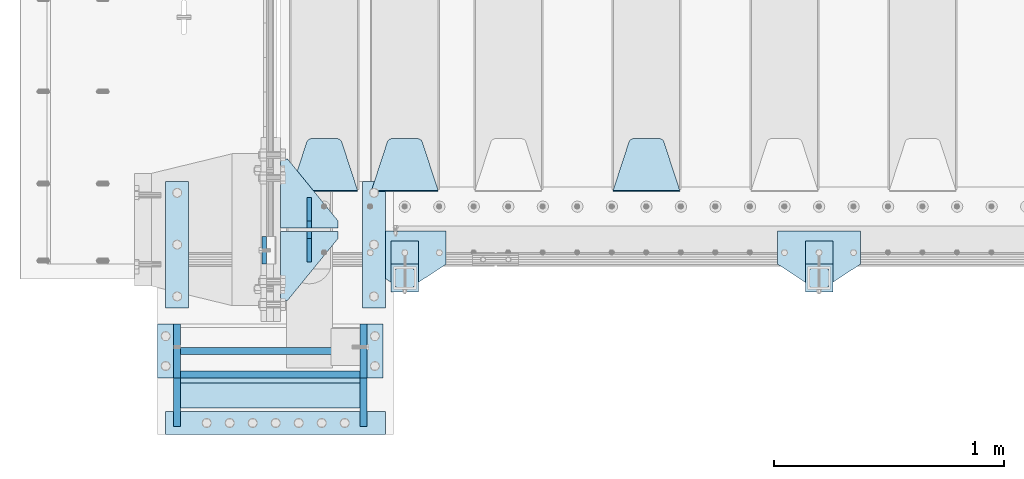
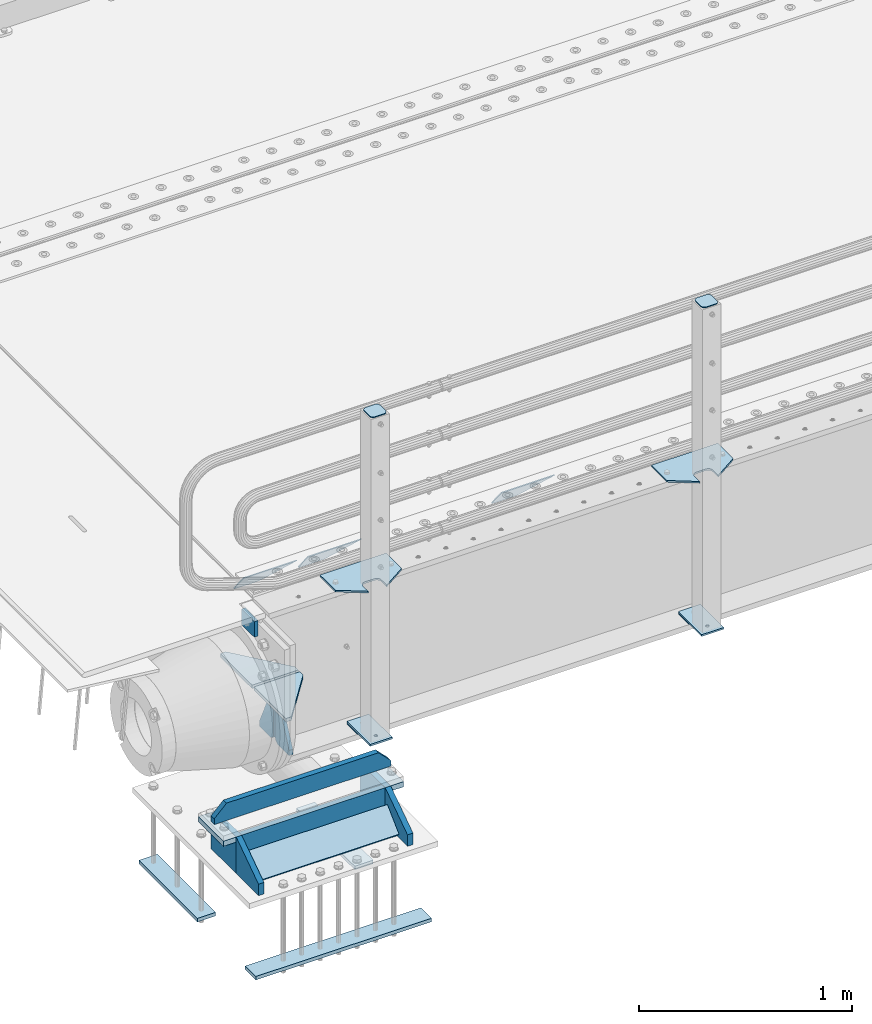
# One storey, part 166 of 208: 28 plates.
"""IFC2X3 building model written with IfcOpenShell, lengths in millimetres."""

from ifc_helpers import new_model, si_unit, frame, origin_with_axes, place, context, subcontext, project, spatial, faceted_brep, material, type_object, element, save


model = new_model("IFC2X3")

# Units and contexts
model_context = context("Model", 3, precision=1e-05, world=origin_with_axes())
body_context = subcontext(model_context, "Body", "Model", "MODEL_VIEW")
ifc_project = project(units=[si_unit("LENGTHUNIT", "METRE", prefix="MILLI"), si_unit("AREAUNIT", "SQUARE_METRE"), si_unit("VOLUMEUNIT", "CUBIC_METRE"), si_unit("MASSUNIT", "GRAM", prefix="KILO"), si_unit("TIMEUNIT", "SECOND"), si_unit("PLANEANGLEUNIT", "RADIAN"), si_unit("SOLIDANGLEUNIT", "STERADIAN"), si_unit("THERMODYNAMICTEMPERATUREUNIT", "DEGREE_CELSIUS"), si_unit("LUMINOUSINTENSITYUNIT", "LUMEN")], contexts=[model_context])

# Site, building, storey
site_placement = place(None, origin_with_axes())
site = spatial("IfcSite", under=ifc_project, at=site_placement, CompositionType="ELEMENT")
building_placement = place(site_placement, origin_with_axes())
building = spatial("IfcBuilding", under=site, at=building_placement, Name="Standard", CompositionType="ELEMENT")
storey_placement = place(building_placement, origin_with_axes())
storey = spatial("IfcBuildingStorey", under=building, at=storey_placement, Name="Undefined", CompositionType="ELEMENT", Elevation=0.0)

# Plates
ifc_material_1 = material(Name="STEEL/S355N")
plate_type_1 = type_object("IfcPlateType", PredefinedType="NOTDEFINED")
plate_1_placement = place(storey_placement, frame((-42510.0, -29.9995540188065, -106.00008741594), z_axis=(1.0000003385235e-09, -0.999999999987744, -4.95099999993936e-06), x_axis=(0.0, -4.95099999998473e-06, 0.999999999987744)))
element("IfcPlate", 1, at=plate_1_placement, inside=storey, type_object=plate_type_1, material=ifc_material_1, context=body_context, shape_type="Brep", body=[
    faceted_brep([(0.0, -10.0, 0.0), (5.7072624315424e-07, -10.0, 120.0), (5.7072624315424e-07, 10.0, 120.0), (0.0, 10.0, 0.0), (90.0, -10.0, 120.0), (90.0, 10.0, 120.0), (90.0, -10.0, 1.09139364212751e-11), (90.0, 10.0, 1.09139364212751e-11)], [[[0, 1, 2, 3]], [[1, 4, 5, 2]], [[4, 6, 7, 5]], [[6, 0, 3, 7]], [[5, 7, 3, 2]], [[6, 4, 1, 0]]]),
])
plate_type_2 = type_object("IfcPlateType", PredefinedType="NOTDEFINED")
plate_2_placement = place(storey_placement, frame((-40705.0, 168.232233047023, -1.76776695296758), z_axis=(0.0, 0.707106781186547, -0.707106781186548), x_axis=(-1.0, 0.0, 0.0)))
element("IfcPlate", 2, at=plate_2_placement, inside=storey, type_object=plate_type_2, material=ifc_material_1, context=body_context, shape_type="Brep", body=[
    faceted_brep([(0.0, -2.5, 0.0), (69.345504679477, -2.5, 300.17173142483), (69.345504679477, 2.5, 300.17173142483), (0.0, 2.5, 0.0), (70.9274061199576, -2.5, 304.897442415399), (70.9274061199576, 2.5, 304.8974424154), (73.3818627772307, -2.5, 309.234538108527), (73.3818627772307, 2.5, 309.234538108527), (76.6187032999551, -2.5, 313.023683126103), (76.6187032999551, 2.5, 313.023683126103), (80.5190132704993, -2.5, 316.125672595371), (80.5190132704993, 2.5, 316.125672595371), (84.9395038596849, -2.5, 318.426546230476), (84.9395038596849, 2.50000000000091, 318.426546230476), (89.7177759439219, -2.5, 319.841774983275), (89.7177759439219, 2.50000000000091, 319.841774983275), (94.678286292652, -2.49999999999909, 320.319366455078), (94.678286292652, 2.5, 320.319366455078), (195.321713707348, -2.49999999999909, 320.319366455078), (195.321713707348, 2.5, 320.319366455078), (200.282224056078, -2.5, 319.841774983275), (200.282224056078, 2.5, 319.841774983274), (205.060496140315, -2.5, 318.426546230475), (205.060496140315, 2.5, 318.426546230475), (209.480986729501, -2.5, 316.125672595371), (209.480986729501, 2.50000000000091, 316.125672595371), (213.381296700045, -2.5, 313.023683126102), (213.381296700045, 2.5, 313.023683126102), (216.618137222769, -2.5, 309.234538108526), (216.618137222769, 2.5, 309.234538108527), (219.072593880042, -2.5, 304.897442415399), (219.072593880042, 2.5, 304.897442415399), (220.654495320523, -2.5, 300.17173142483), (220.654495320523, 2.5, 300.17173142483), (290.0, -2.5, 0.0), (290.0, 2.5, 0.0)], [[[0, 1, 2, 3]], [[1, 4, 5, 2]], [[4, 6, 7, 5]], [[6, 8, 9, 7]], [[8, 10, 11, 9]], [[10, 12, 13, 11]], [[12, 14, 15, 13]], [[14, 16, 17, 15]], [[16, 18, 19, 17]], [[18, 20, 21, 19]], [[20, 22, 23, 21]], [[22, 24, 25, 23]], [[24, 26, 27, 25]], [[26, 28, 29, 27]], [[28, 30, 31, 29]], [[30, 32, 33, 31]], [[32, 34, 35, 33]], [[34, 0, 3, 35]], [[5, 7, 9, 11, 13, 15, 17, 19, 21, 23, 25, 27, 29, 31, 33, 35, 3, 2]], [[34, 32, 30, 28, 26, 24, 22, 20, 18, 16, 14, 12, 10, 8, 6, 4, 1, 0]]]),
])
plate_3_placement = place(storey_placement, frame((-41755.0, 168.232233047023, -1.76776695296758), z_axis=(0.0, 0.707106781186547, -0.707106781186548), x_axis=(-1.0, 0.0, 0.0)))
element("IfcPlate", 3, at=plate_3_placement, inside=storey, type_object=plate_type_2, material=ifc_material_1, context=body_context, shape_type="Brep", body=[
    faceted_brep([(0.0, -2.5, 0.0), (69.345504679477, -2.5, 300.17173142483), (69.345504679477, 2.5, 300.17173142483), (0.0, 2.5, 0.0), (70.9274061199576, -2.5, 304.897442415399), (70.9274061199576, 2.5, 304.8974424154), (73.3818627772307, -2.5, 309.234538108527), (73.3818627772307, 2.5, 309.234538108527), (76.6187032999551, -2.5, 313.023683126103), (76.6187032999551, 2.5, 313.023683126103), (80.5190132704993, -2.5, 316.125672595371), (80.5190132704993, 2.5, 316.125672595371), (84.9395038596849, -2.5, 318.426546230476), (84.9395038596849, 2.50000000000091, 318.426546230476), (89.7177759439219, -2.5, 319.841774983275), (89.7177759439219, 2.50000000000091, 319.841774983275), (94.678286292652, -2.49999999999909, 320.319366455078), (94.678286292652, 2.5, 320.319366455078), (195.321713707348, -2.49999999999909, 320.319366455078), (195.321713707348, 2.5, 320.319366455078), (200.282224056078, -2.5, 319.841774983275), (200.282224056078, 2.5, 319.841774983274), (205.060496140315, -2.5, 318.426546230475), (205.060496140315, 2.5, 318.426546230475), (209.480986729501, -2.5, 316.125672595371), (209.480986729501, 2.50000000000091, 316.125672595371), (213.381296700045, -2.5, 313.023683126102), (213.381296700045, 2.5, 313.023683126102), (216.618137222769, -2.5, 309.234538108526), (216.618137222769, 2.5, 309.234538108527), (219.072593880042, -2.5, 304.897442415399), (219.072593880042, 2.5, 304.897442415399), (220.654495320523, -2.5, 300.17173142483), (220.654495320523, 2.5, 300.17173142483), (290.0, -2.5, 0.0), (290.0, 2.5, 0.0)], [[[0, 1, 2, 3]], [[1, 4, 5, 2]], [[4, 6, 7, 5]], [[6, 8, 9, 7]], [[8, 10, 11, 9]], [[10, 12, 13, 11]], [[12, 14, 15, 13]], [[14, 16, 17, 15]], [[16, 18, 19, 17]], [[18, 20, 21, 19]], [[20, 22, 23, 21]], [[22, 24, 25, 23]], [[24, 26, 27, 25]], [[26, 28, 29, 27]], [[28, 30, 31, 29]], [[30, 32, 33, 31]], [[32, 34, 35, 33]], [[34, 0, 3, 35]], [[5, 7, 9, 11, 13, 15, 17, 19, 21, 23, 25, 27, 29, 31, 33, 35, 3, 2]], [[34, 32, 30, 28, 26, 24, 22, 20, 18, 16, 14, 12, 10, 8, 6, 4, 1, 0]]]),
])
plate_4_placement = place(storey_placement, frame((-42105.0, 168.232233047023, -1.76776695296758), z_axis=(0.0, 0.707106781186547, -0.707106781186548), x_axis=(-1.0, 0.0, 0.0)))
element("IfcPlate", 4, at=plate_4_placement, inside=storey, type_object=plate_type_2, material=ifc_material_1, context=body_context, shape_type="Brep", body=[
    faceted_brep([(0.0, -2.5, 0.0), (69.345504679477, -2.5, 300.17173142483), (69.345504679477, 2.5, 300.17173142483), (0.0, 2.5, 0.0), (70.9274061199576, -2.5, 304.897442415399), (70.9274061199576, 2.5, 304.8974424154), (73.3818627772307, -2.5, 309.234538108527), (73.3818627772307, 2.5, 309.234538108527), (76.6187032999551, -2.5, 313.023683126103), (76.6187032999551, 2.5, 313.023683126103), (80.5190132704993, -2.5, 316.125672595371), (80.5190132704993, 2.5, 316.125672595371), (84.9395038596849, -2.5, 318.426546230476), (84.9395038596849, 2.50000000000091, 318.426546230476), (89.7177759439219, -2.5, 319.841774983275), (89.7177759439219, 2.50000000000091, 319.841774983275), (94.678286292652, -2.49999999999909, 320.319366455078), (94.678286292652, 2.5, 320.319366455078), (195.321713707348, -2.49999999999909, 320.319366455078), (195.321713707348, 2.5, 320.319366455078), (200.282224056078, -2.5, 319.841774983275), (200.282224056078, 2.5, 319.841774983274), (205.060496140315, -2.5, 318.426546230475), (205.060496140315, 2.5, 318.426546230475), (209.480986729501, -2.5, 316.125672595371), (209.480986729501, 2.50000000000091, 316.125672595371), (213.381296700045, -2.5, 313.023683126102), (213.381296700045, 2.5, 313.023683126102), (216.618137222769, -2.5, 309.234538108526), (216.618137222769, 2.5, 309.234538108527), (219.072593880042, -2.5, 304.897442415399), (219.072593880042, 2.5, 304.897442415399), (220.654495320523, -2.5, 300.17173142483), (220.654495320523, 2.5, 300.17173142483), (290.0, -2.5, 0.0), (290.0, 2.5, 0.0)], [[[0, 1, 2, 3]], [[1, 4, 5, 2]], [[4, 6, 7, 5]], [[6, 8, 9, 7]], [[8, 10, 11, 9]], [[10, 12, 13, 11]], [[12, 14, 15, 13]], [[14, 16, 17, 15]], [[16, 18, 19, 17]], [[18, 20, 21, 19]], [[20, 22, 23, 21]], [[22, 24, 25, 23]], [[24, 26, 27, 25]], [[26, 28, 29, 27]], [[28, 30, 31, 29]], [[30, 32, 33, 31]], [[32, 34, 35, 33]], [[34, 0, 3, 35]], [[5, 7, 9, 11, 13, 15, 17, 19, 21, 23, 25, 27, 29, 31, 33, 35, 3, 2]], [[34, 32, 30, 28, 26, 24, 22, 20, 18, 16, 14, 12, 10, 8, 6, 4, 1, 0]]]),
])
plate_type_3 = type_object("IfcPlateType", PredefinedType="NOTDEFINED")
for number, where, z_axis, x_axis in (
    (5, (-42190.0, 8.0, -515.0), (0.0, 1.0, 0.0), (-1.0, 0.0, 0.0)),
    (6, (-42190.0, -8.0, -515.0), (0.0, -1.0, 0.0), (-1.0, 0.0, 0.0)),
):
    element("IfcPlate", number, at=place(storey_placement, frame(where, z_axis=z_axis, x_axis=x_axis)), inside=storey, type_object=plate_type_3, material=ifc_material_1, context=body_context, shape_type="Brep", body=[
        faceted_brep([(0.0, -10.0, 0.0), (0.0, -10.0, 30.0), (0.0, 10.0, 30.0), (0.0, 10.0, 0.0), (220.0, -10.0, 300.0), (220.0, 10.0, 300.0), (250.0, -10.0, 300.0), (250.0, 10.0, 300.0), (250.0, -10.0, 0.0), (250.0, 10.0, 0.0)], [[[0, 1, 2, 3]], [[1, 4, 5, 2]], [[4, 6, 7, 5]], [[6, 8, 9, 7]], [[8, 0, 3, 9]], [[5, 7, 9, 3, 2]], [[8, 6, 4, 1, 0]]]),
    ])
plate_type_4 = type_object("IfcPlateType", PredefinedType="NOTDEFINED")
for number, where, z_axis, x_axis in (
    (7, (-42315.0, 140.0, -860.0), (0.0, 0.0, 1.0), (0.0, -1.0, 0.0)),
    (8, (-42315.0, -140.0, -860.0), (0.0, 0.0, 1.0), (0.0, 1.0, 0.0)),
):
    element("IfcPlate", number, at=place(storey_placement, frame(where, z_axis=z_axis, x_axis=x_axis)), inside=storey, type_object=plate_type_4, material=ifc_material_1, context=body_context, shape_type="Brep", body=[
        faceted_brep([(0.0, -10.0, 0.0), (0.0, -10.0, 30.0), (0.0, 10.0, 30.0), (0.0, 10.0, 0.0), (102.0, -10.0, 250.0), (102.0, 10.0, 250.0), (132.0, -10.0, 250.0), (132.0, 10.0, 250.0), (132.0, -10.0, 30.0), (132.0, 10.0, 30.0), (131.544232590366, -10.0, 24.790554669992), (131.544232590366, 10.0, 24.790554669992), (130.190778623577, -10.0, 19.7393957002299), (130.190778623577, 10.0, 19.7393957002299), (127.980762113533, -10.0, 15.0), (127.980762113533, 10.0, 15.0), (124.981333293569, -10.0, 10.7163717094038), (124.981333293569, 10.0, 10.7163717094038), (121.283628290596, -10.0, 7.01866670643062), (121.283628290596, 10.0, 7.01866670643062), (117.0, -10.0, 4.01923788646684), (117.0, 10.0, 4.01923788646684), (112.26060429977, -10.0, 1.80922137642278), (112.26060429977, 10.0, 1.80922137642278), (107.209445330008, -10.0, 0.455767409633722), (107.209445330008, 10.0, 0.455767409633722), (102.0, -10.0, 0.0), (102.0, 10.0, 0.0)], [[[0, 1, 2, 3]], [[1, 4, 5, 2]], [[4, 6, 7, 5]], [[6, 8, 9, 7]], [[8, 10, 11, 9]], [[10, 12, 13, 11]], [[12, 14, 15, 13]], [[14, 16, 17, 15]], [[16, 18, 19, 17]], [[18, 20, 21, 19]], [[20, 22, 23, 21]], [[22, 24, 25, 23]], [[24, 26, 27, 25]], [[26, 0, 3, 27]], [[5, 7, 9, 11, 13, 15, 17, 19, 21, 23, 25, 27, 3, 2]], [[26, 24, 22, 20, 18, 16, 14, 12, 10, 8, 6, 4, 1, 0]]]),
    ])
ifc_material_2 = material(Name="STEEL/S355J2")
plate_type_5 = type_object("IfcPlateType", PredefinedType="NOTDEFINED")
plate_5_placement = place(storey_placement, frame((-39920.0, -4.99999999999636, 5.00000000004911), z_axis=(0.0, -1.0, 0.0), x_axis=(-1.0, 0.0, 0.0)))
element("IfcPlate", 9, at=plate_5_placement, inside=storey, type_object=plate_type_5, material=ifc_material_2, context=body_context, shape_type="Brep", body=[
    faceted_brep([(0.0, -5.0, 0.0), (2.31396552408114e-06, -5.0, 145.0), (2.31396552408114e-06, 5.0, 145.0), (0.0, 5.0, 0.0), (130.0, -5.0, 230.0), (130.0, 5.0, 230.0), (130.0, -5.0, 180.0), (130.0, 5.0, 180.0), (130.48036798992, -5.0, 175.122741949597), (130.48036798992, 5.0, 175.122741949597), (131.903011687216, -5.0, 170.432914190873), (131.903011687216, 5.0, 170.432914190873), (134.213259692435, -5.0, 166.11074417451), (134.213259692435, 5.0, 166.11074417451), (137.322330470335, -5.0, 162.322330470336), (137.322330470335, 5.0, 162.322330470336), (141.110744174512, -5.0, 159.213259692437), (141.110744174512, 5.0, 159.213259692437), (145.432914190871, -5.0, 156.903011687218), (145.432914190871, 5.0, 156.903011687218), (150.122741949595, -5.0, 155.48036798992), (150.122741949595, 5.0, 155.48036798992), (155.0, -5.0, 155.0), (155.0, 5.0, 155.0), (205.0, -5.0, 155.0), (205.0, 5.0, 155.0), (209.877258050405, -5.0, 155.48036798992), (209.877258050405, 5.0, 155.48036798992), (214.567085809129, -5.0, 156.903011687218), (214.567085809129, 5.0, 156.903011687218), (218.889255825488, -5.0, 159.213259692437), (218.889255825488, 5.0, 159.213259692437), (222.677669529665, -5.0, 162.322330470336), (222.677669529665, 5.0, 162.322330470336), (225.786740307565, -5.0, 166.11074417451), (225.786740307565, 5.0, 166.11074417451), (228.096988312784, -5.0, 170.432914190873), (228.096988312784, 5.0, 170.432914190873), (229.51963201008, -5.0, 175.122741949597), (229.51963201008, 5.0, 175.122741949597), (230.0, -5.0, 180.0), (230.0, 5.0, 180.0), (230.0, -5.0, 230.0), (230.0, 5.0, 230.0), (360.0, -5.0, 145.0), (360.0, 5.0, 145.0), (360.0, -5.0, -7.27595761418343e-12), (360.0, 5.0, -7.27595761418343e-12)], [[[0, 1, 2, 3]], [[1, 4, 5, 2]], [[4, 6, 7, 5]], [[6, 8, 9, 7]], [[8, 10, 11, 9]], [[10, 12, 13, 11]], [[12, 14, 15, 13]], [[14, 16, 17, 15]], [[16, 18, 19, 17]], [[18, 20, 21, 19]], [[20, 22, 23, 21]], [[22, 24, 25, 23]], [[24, 26, 27, 25]], [[26, 28, 29, 27]], [[28, 30, 31, 29]], [[30, 32, 33, 31]], [[32, 34, 35, 33]], [[34, 36, 37, 35]], [[36, 38, 39, 37]], [[38, 40, 41, 39]], [[40, 42, 43, 41]], [[42, 44, 45, 43]], [[44, 46, 47, 45]], [[46, 0, 3, 47]], [[5, 7, 9, 11, 13, 15, 17, 19, 21, 23, 25, 27, 29, 31, 33, 35, 37, 39, 41, 43, 45, 47, 3, 2]], [[46, 44, 42, 40, 38, 36, 34, 32, 30, 28, 26, 24, 22, 20, 18, 16, 14, 12, 10, 8, 6, 4, 1, 0]]]),
])
plate_6_placement = place(storey_placement, frame((-41720.0, -4.99999999999636, 5.00000000004911), z_axis=(0.0, -1.0, 0.0), x_axis=(-1.0, 0.0, 0.0)))
element("IfcPlate", 10, at=plate_6_placement, inside=storey, type_object=plate_type_5, material=ifc_material_2, context=body_context, shape_type="Brep", body=[
    faceted_brep([(0.0, -5.0, 0.0), (2.31396552408114e-06, -5.0, 145.0), (2.31396552408114e-06, 5.0, 145.0), (0.0, 5.0, 0.0), (130.0, -5.0, 230.0), (130.0, 5.0, 230.0), (130.0, -5.0, 180.0), (130.0, 5.0, 180.0), (130.48036798992, -5.0, 175.122741949597), (130.48036798992, 5.0, 175.122741949597), (131.903011687216, -5.0, 170.432914190873), (131.903011687216, 5.0, 170.432914190873), (134.213259692435, -5.0, 166.11074417451), (134.213259692435, 5.0, 166.11074417451), (137.322330470335, -5.0, 162.322330470336), (137.322330470335, 5.0, 162.322330470336), (141.110744174512, -5.0, 159.213259692437), (141.110744174512, 5.0, 159.213259692437), (145.432914190871, -5.0, 156.903011687218), (145.432914190871, 5.0, 156.903011687218), (150.122741949595, -5.0, 155.48036798992), (150.122741949595, 5.0, 155.48036798992), (155.0, -5.0, 155.0), (155.0, 5.0, 155.0), (205.0, -5.0, 155.0), (205.0, 5.0, 155.0), (209.877258050405, -5.0, 155.48036798992), (209.877258050405, 5.0, 155.48036798992), (214.567085809129, -5.0, 156.903011687218), (214.567085809129, 5.0, 156.903011687218), (218.889255825488, -5.0, 159.213259692437), (218.889255825488, 5.0, 159.213259692437), (222.677669529665, -5.0, 162.322330470336), (222.677669529665, 5.0, 162.322330470336), (225.786740307565, -5.0, 166.11074417451), (225.786740307565, 5.0, 166.11074417451), (228.096988312784, -5.0, 170.432914190873), (228.096988312784, 5.0, 170.432914190873), (229.51963201008, -5.0, 175.122741949597), (229.51963201008, 5.0, 175.122741949597), (230.0, -5.0, 180.0), (230.0, 5.0, 180.0), (230.0, -5.0, 230.0), (230.0, 5.0, 230.0), (360.0, -5.0, 145.0), (360.0, 5.0, 145.0), (360.0, -5.0, -7.27595761418343e-12), (360.0, 5.0, -7.27595761418343e-12)], [[[0, 1, 2, 3]], [[1, 4, 5, 2]], [[4, 6, 7, 5]], [[6, 8, 9, 7]], [[8, 10, 11, 9]], [[10, 12, 13, 11]], [[12, 14, 15, 13]], [[14, 16, 17, 15]], [[16, 18, 19, 17]], [[18, 20, 21, 19]], [[20, 22, 23, 21]], [[22, 24, 25, 23]], [[24, 26, 27, 25]], [[26, 28, 29, 27]], [[28, 30, 31, 29]], [[30, 32, 33, 31]], [[32, 34, 35, 33]], [[34, 36, 37, 35]], [[36, 38, 39, 37]], [[38, 40, 41, 39]], [[40, 42, 43, 41]], [[42, 44, 45, 43]], [[44, 46, 47, 45]], [[46, 0, 3, 47]], [[5, 7, 9, 11, 13, 15, 17, 19, 21, 23, 25, 27, 29, 31, 33, 35, 37, 39, 41, 43, 45, 47, 3, 2]], [[46, 44, 42, 40, 38, 36, 34, 32, 30, 28, 26, 24, 22, 20, 18, 16, 14, 12, 10, 8, 6, 4, 1, 0]]]),
])
plate_type_6 = type_object("IfcPlateType", PredefinedType="NOTDEFINED")
for number, where, z_axis, x_axis in (
    (11, (-40040.0000000001, -50.0000000002074, -850.000000000002), (0.0, -1.0, 0.0), (-1.0, 0.0, 0.0)),
    (12, (-41840.0000000001, -50.0000000002074, -850.000000000002), (0.0, -1.0, 0.0), (-1.0, 0.0, 0.0)),
):
    element("IfcPlate", number, at=place(storey_placement, frame(where, z_axis=z_axis, x_axis=x_axis)), inside=storey, type_object=plate_type_6, material=ifc_material_2, context=body_context, shape_type="Brep", body=[
        faceted_brep([(53.6360389691836, -5.0, 176.36396103047), (53.6360389691836, 5.0, 176.36396103047), (59.9999999998618, 5.0, 178.999999999791), (59.9999999998618, -5.0, 178.999999999791), (66.3639610305399, 5.0, 176.36396103047), (66.3639610305399, -5.0, 176.36396103047), (68.9999999998618, 5.0, 169.999999999791), (68.9999999998618, -5.0, 169.999999999791), (66.3639610305399, 5.0, 163.636038969112), (66.3639610305399, -5.0, 163.636038969112), (59.9999999998618, 5.0, 160.999999999791), (59.9999999998618, -5.0, 160.999999999791), (53.6360389691836, 5.0, 163.636038969112), (53.6360389691836, -5.0, 163.636038969112), (50.9999999998618, 5.0, 169.999999999791), (50.9999999998618, -5.0, 169.999999999791), (120.0, -5.0, 0.0), (120.0, -5.0, 220.0), (0.0, -5.0, 220.0), (0.0, -5.0, 0.0), (0.0, 5.0, 0.0), (120.0, 5.0, 0.0), (120.0, 5.0, 220.0), (0.0, 5.0, 220.0)], [[[0, 1, 2, 3]], [[3, 2, 4, 5]], [[5, 4, 6, 7]], [[7, 6, 8, 9]], [[9, 8, 10, 11]], [[11, 10, 12, 13]], [[13, 12, 14, 15]], [[15, 14, 1, 0]], [[16, 17, 18, 19], [11, 13, 15, 0, 3, 5, 7, 9]], [[16, 19, 20, 21]], [[17, 16, 21, 22]], [[18, 17, 22, 23]], [[19, 18, 23, 20]], [[22, 21, 20, 23], [2, 1, 14, 12, 10, 8, 6, 4]]]),
    ])
plate_type_7 = type_object("IfcPlateType", PredefinedType="NOTDEFINED")
plate_7_placement = place(storey_placement, frame((-40144.0000000001, -166.000000000207, 1012.50000000001), z_axis=(0.0, -1.0, 0.0), x_axis=(1.0, 0.0, 0.0)))
element("IfcPlate", 13, at=plate_7_placement, inside=storey, type_object=plate_type_7, material=ifc_material_2, context=body_context, shape_type="Brep", body=[
    faceted_brep([(0.0, -2.5, 19.0), (0.0, -2.5, 69.0), (0.0, 2.5, 69.0), (0.0, 2.5, 19.0), (0.476369668544066, -2.5, 73.2278977451697), (0.476369668544066, 2.5, 73.2278977451697), (1.88159150985302, -2.5, 77.2437910432336), (1.88159150985302, 2.5, 77.2437910432336), (4.14520183310742, -2.5, 80.8463062353158), (4.14520183310742, 2.5, 80.8463062353158), (7.15369376468516, -2.5, 83.8547981668926), (7.15369376468516, 2.5, 83.8547981668926), (10.7562089567655, -2.5, 86.1184084901461), (10.7562089567655, 2.5, 86.1184084901461), (14.7721022548285, -2.5, 87.523630331455), (14.7721022548285, 2.5, 87.523630331455), (19.0, -2.5, 88.0), (19.0, 2.5, 88.0), (69.0, -2.5, 88.0), (69.0, 2.5, 88.0), (73.2278977451715, -2.5, 87.523630331455), (73.2278977451715, 2.5, 87.523630331455), (77.2437910432345, -2.5, 86.1184084901461), (77.2437910432345, 2.5, 86.1184084901461), (80.8463062353148, -2.5, 83.8547981668926), (80.8463062353148, 2.5, 83.8547981668926), (83.8547981668926, -2.5, 80.8463062353158), (83.8547981668926, 2.5, 80.8463062353158), (86.118408490147, -2.5, 77.2437910432336), (86.118408490147, 2.5, 77.2437910432336), (87.5236303314559, -2.5, 73.2278977451697), (87.5236303314559, 2.5, 73.2278977451697), (88.0, -2.5, 69.0), (88.0, 2.5, 69.0), (88.0, -2.5, 19.0), (88.0, 2.5, 19.0), (87.5236303314559, -2.5, 14.7721022548303), (87.5236303314559, 2.5, 14.7721022548303), (86.118408490147, -2.5, 10.7562089567664), (86.118408490147, 2.5, 10.7562089567664), (83.8547981668926, -2.5, 7.15369376468425), (83.8547981668926, 2.5, 7.15369376468425), (80.8463062353148, -2.5, 4.14520183310742), (80.8463062353148, 2.5, 4.14520183310742), (77.2437910432345, -2.5, 1.88159150985393), (77.2437910432345, 2.5, 1.88159150985393), (73.2278977451715, -2.5, 0.476369668544976), (73.2278977451715, 2.5, 0.476369668544976), (69.0, -2.5, 0.0), (69.0, 2.5, 0.0), (19.0, -2.5, 0.0), (19.0, 2.5, 0.0), (14.7721022548285, -2.5, 0.476369668544976), (14.7721022548285, 2.5, 0.476369668544976), (10.7562089567655, -2.5, 1.88159150985393), (10.7562089567655, 2.5, 1.88159150985393), (7.15369376468516, -2.5, 4.14520183310742), (7.15369376468516, 2.5, 4.14520183310742), (4.14520183310742, -2.5, 7.15369376468425), (4.14520183310742, 2.5, 7.15369376468425), (1.88159150985302, -2.5, 10.7562089567664), (1.88159150985302, 2.5, 10.7562089567664), (0.476369668544066, -2.5, 14.7721022548303), (0.476369668544066, 2.5, 14.7721022548303)], [[[0, 1, 2, 3]], [[1, 4, 5, 2]], [[4, 6, 7, 5]], [[6, 8, 9, 7]], [[8, 10, 11, 9]], [[10, 12, 13, 11]], [[12, 14, 15, 13]], [[14, 16, 17, 15]], [[16, 18, 19, 17]], [[18, 20, 21, 19]], [[20, 22, 23, 21]], [[22, 24, 25, 23]], [[24, 26, 27, 25]], [[26, 28, 29, 27]], [[28, 30, 31, 29]], [[30, 32, 33, 31]], [[32, 34, 35, 33]], [[34, 36, 37, 35]], [[36, 38, 39, 37]], [[38, 40, 41, 39]], [[40, 42, 43, 41]], [[42, 44, 45, 43]], [[44, 46, 47, 45]], [[46, 48, 49, 47]], [[48, 50, 51, 49]], [[50, 52, 53, 51]], [[52, 54, 55, 53]], [[54, 56, 57, 55]], [[56, 58, 59, 57]], [[58, 60, 61, 59]], [[60, 62, 63, 61]], [[62, 0, 3, 63]], [[5, 7, 9, 11, 13, 15, 17, 19, 21, 23, 25, 27, 29, 31, 33, 35, 37, 39, 41, 43, 45, 47, 49, 51, 53, 55, 57, 59, 61, 63, 3, 2]], [[62, 60, 58, 56, 54, 52, 50, 48, 46, 44, 42, 40, 38, 36, 34, 32, 30, 28, 26, 24, 22, 20, 18, 16, 14, 12, 10, 8, 6, 4, 1, 0]]]),
])
plate_8_placement = place(storey_placement, frame((-41944.0000000001, -166.000000000207, 1012.50000000001), z_axis=(0.0, -1.0, 0.0), x_axis=(1.0, 0.0, 0.0)))
element("IfcPlate", 14, at=plate_8_placement, inside=storey, type_object=plate_type_7, material=ifc_material_2, context=body_context, shape_type="Brep", body=[
    faceted_brep([(0.0, -2.5, 19.0), (0.0, -2.5, 69.0), (0.0, 2.5, 69.0), (0.0, 2.5, 19.0), (0.476369668544066, -2.5, 73.2278977451697), (0.476369668544066, 2.5, 73.2278977451697), (1.88159150985302, -2.5, 77.2437910432336), (1.88159150985302, 2.5, 77.2437910432336), (4.14520183310742, -2.5, 80.8463062353158), (4.14520183310742, 2.5, 80.8463062353158), (7.15369376468516, -2.5, 83.8547981668926), (7.15369376468516, 2.5, 83.8547981668926), (10.7562089567655, -2.5, 86.1184084901461), (10.7562089567655, 2.5, 86.1184084901461), (14.7721022548285, -2.5, 87.523630331455), (14.7721022548285, 2.5, 87.523630331455), (19.0, -2.5, 88.0), (19.0, 2.5, 88.0), (69.0, -2.5, 88.0), (69.0, 2.5, 88.0), (73.2278977451715, -2.5, 87.523630331455), (73.2278977451715, 2.5, 87.523630331455), (77.2437910432345, -2.5, 86.1184084901461), (77.2437910432345, 2.5, 86.1184084901461), (80.8463062353148, -2.5, 83.8547981668926), (80.8463062353148, 2.5, 83.8547981668926), (83.8547981668926, -2.5, 80.8463062353158), (83.8547981668926, 2.5, 80.8463062353158), (86.118408490147, -2.5, 77.2437910432336), (86.118408490147, 2.5, 77.2437910432336), (87.5236303314559, -2.5, 73.2278977451697), (87.5236303314559, 2.5, 73.2278977451697), (88.0, -2.5, 69.0), (88.0, 2.5, 69.0), (88.0, -2.5, 19.0), (88.0, 2.5, 19.0), (87.5236303314559, -2.5, 14.7721022548303), (87.5236303314559, 2.5, 14.7721022548303), (86.118408490147, -2.5, 10.7562089567664), (86.118408490147, 2.5, 10.7562089567664), (83.8547981668926, -2.5, 7.15369376468425), (83.8547981668926, 2.5, 7.15369376468425), (80.8463062353148, -2.5, 4.14520183310742), (80.8463062353148, 2.5, 4.14520183310742), (77.2437910432345, -2.5, 1.88159150985393), (77.2437910432345, 2.5, 1.88159150985393), (73.2278977451715, -2.5, 0.476369668544976), (73.2278977451715, 2.5, 0.476369668544976), (69.0, -2.5, 0.0), (69.0, 2.5, 0.0), (19.0, -2.5, 0.0), (19.0, 2.5, 0.0), (14.7721022548285, -2.5, 0.476369668544976), (14.7721022548285, 2.5, 0.476369668544976), (10.7562089567655, -2.5, 1.88159150985393), (10.7562089567655, 2.5, 1.88159150985393), (7.15369376468516, -2.5, 4.14520183310742), (7.15369376468516, 2.5, 4.14520183310742), (4.14520183310742, -2.5, 7.15369376468425), (4.14520183310742, 2.5, 7.15369376468425), (1.88159150985302, -2.5, 10.7562089567664), (1.88159150985302, 2.5, 10.7562089567664), (0.476369668544066, -2.5, 14.7721022548303), (0.476369668544066, 2.5, 14.7721022548303)], [[[0, 1, 2, 3]], [[1, 4, 5, 2]], [[4, 6, 7, 5]], [[6, 8, 9, 7]], [[8, 10, 11, 9]], [[10, 12, 13, 11]], [[12, 14, 15, 13]], [[14, 16, 17, 15]], [[16, 18, 19, 17]], [[18, 20, 21, 19]], [[20, 22, 23, 21]], [[22, 24, 25, 23]], [[24, 26, 27, 25]], [[26, 28, 29, 27]], [[28, 30, 31, 29]], [[30, 32, 33, 31]], [[32, 34, 35, 33]], [[34, 36, 37, 35]], [[36, 38, 39, 37]], [[38, 40, 41, 39]], [[40, 42, 43, 41]], [[42, 44, 45, 43]], [[44, 46, 47, 45]], [[46, 48, 49, 47]], [[48, 50, 51, 49]], [[50, 52, 53, 51]], [[52, 54, 55, 53]], [[54, 56, 57, 55]], [[56, 58, 59, 57]], [[58, 60, 61, 59]], [[60, 62, 63, 61]], [[62, 0, 3, 63]], [[5, 7, 9, 11, 13, 15, 17, 19, 21, 23, 25, 27, 29, 31, 33, 35, 37, 39, 41, 43, 45, 47, 49, 51, 53, 55, 57, 59, 61, 63, 3, 2]], [[62, 60, 58, 56, 54, 52, 50, 48, 46, 44, 42, 40, 38, 36, 34, 32, 30, 28, 26, 24, 22, 20, 18, 16, 14, 12, 10, 8, 6, 4, 1, 0]]]),
])
plate_type_8 = type_object("IfcPlateType", PredefinedType="NOTDEFINED")
for number, where, z_axis, x_axis in (
    (15, (-40040.0000000001, -50.0000000002074, -857.500000000002), (0.0, -1.0, 0.0), (-1.0, 0.0, 0.0)),
    (16, (-41840.0000000001, -50.0000000002074, -857.500000000002), (0.0, -1.0, 0.0), (-1.0, 0.0, 0.0)),
):
    element("IfcPlate", number, at=place(storey_placement, frame(where, z_axis=z_axis, x_axis=x_axis)), inside=storey, type_object=plate_type_8, material=ifc_material_2, context=body_context, shape_type="Brep", body=[
        faceted_brep([(0.0, -2.5, 0.0), (0.0, -2.5, 100.0), (0.0, 2.5, 100.0), (0.0, 2.5, 0.0), (120.0, -2.5, 100.0), (120.0, 2.5, 100.0), (120.0, -2.5, 0.0), (120.0, 2.5, 0.0)], [[[0, 1, 2, 3]], [[1, 4, 5, 2]], [[4, 6, 7, 5]], [[6, 0, 3, 7]], [[5, 7, 3, 2]], [[6, 4, 1, 0]]]),
    ])
plate_type_9 = type_object("IfcPlateType", PredefinedType="NOTDEFINED")
plate_9_placement = place(storey_placement, frame((-42095.0, -765.357134753238, -1017.14966545662), z_axis=(-1.0, 0.0, 0.0), x_axis=(0.0, 0.723355636225728, 0.690475650215467)))
element("IfcPlate", 17, at=plate_9_placement, inside=storey, type_object=plate_type_9, material=ifc_material_1, context=body_context, shape_type="Brep", body=[
    faceted_brep([(0.0, -15.0, 0.0), (-9.09494701772928e-13, -15.0, 779.0), (-1.81898940354586e-12, 15.0000000000009, 779.0), (0.0, 15.0, 0.0), (152.069061279296, -14.9999999999995, 779.0), (152.069061279296, 15.0, 779.0), (152.069061279296, -14.9999999999995, 0.0), (152.069061279296, 15.0, 0.0)], [[[0, 1, 2, 3]], [[1, 4, 5, 2]], [[4, 6, 7, 5]], [[6, 0, 3, 7]], [[5, 7, 3, 2]], [[6, 4, 1, 0]]]),
])
plate_type_10 = type_object("IfcPlateType", PredefinedType="NOTDEFINED")
for number, where, z_axis, x_axis in (
    (18, (-42084.0, -339.999998533764, -1468.0), (0.0, 1.0, 0.0), (1.0, 0.0, 0.0)),
    (19, (-42939.0, -339.999998533764, -1468.0), (0.0, 1.0, 0.0), (1.0, 0.0, 0.0)),
):
    element("IfcPlate", number, at=place(storey_placement, frame(where, z_axis=z_axis, x_axis=x_axis)), inside=storey, type_object=plate_type_10, material=ifc_material_1, context=body_context, shape_type="Brep", body=[
        faceted_brep([(0.0, -10.0, 0.0), (1.00942997960374e-06, -10.0, 550.0), (1.00942997960374e-06, 10.0, 550.0), (0.0, 10.0, 0.0), (100.0, -10.0, 550.0), (100.0, 10.0, 550.0), (100.0, -10.0, 0.0), (100.0, 10.0, 0.0)], [[[0, 1, 2, 3]], [[1, 4, 5, 2]], [[4, 6, 7, 5]], [[6, 0, 3, 7]], [[5, 7, 3, 2]], [[6, 4, 1, 0]]]),
    ])
plate_10_placement = place(storey_placement, frame((-42939.0, -889.999998533764, -1468.0), z_axis=(0.0, 1.0, 0.0), x_axis=(1.0, 0.0, 0.0)))
element("IfcPlate", 20, at=plate_10_placement, inside=storey, type_object=plate_type_10, material=ifc_material_1, context=body_context, shape_type="Brep", body=[
    faceted_brep([(0.0, -10.0, 0.0), (0.0, -10.0, 100.0), (0.0, 10.0, 100.0), (0.0, 10.0, 0.0), (955.0, -10.0, 100.0), (955.0, 10.0, 100.0), (955.0, -10.0, 0.0), (955.0, 10.0, 0.0)], [[[0, 1, 2, 3]], [[1, 4, 5, 2]], [[4, 6, 7, 5]], [[6, 0, 3, 7]], [[5, 7, 3, 2]], [[6, 4, 1, 0]]]),
])
plate_type_11 = type_object("IfcPlateType", PredefinedType="NOTDEFINED")
plate_11_placement = place(storey_placement, frame((-42080.0, -410.0, -818.000000000005), z_axis=(0.0, 0.0, -1.0), x_axis=(0.0, -1.0, 0.0)))
element("IfcPlate", 21, at=plate_11_placement, inside=storey, type_object=plate_type_11, material=ifc_material_1, context=body_context, shape_type="Brep", body=[
    faceted_brep([(0.0, -15.0, 0.0), (0.0, -15.0, 210.0), (0.0, 15.0, 210.0), (0.0, 15.0, 0.0), (235.0, -15.0, 210.0), (235.0, 15.0, 210.0), (235.0, -15.0, 0.0), (235.0, 15.0, 0.0)], [[[0, 1, 2, 3]], [[1, 4, 5, 2]], [[4, 6, 7, 5]], [[6, 0, 3, 7]], [[5, 7, 3, 2]], [[6, 4, 1, 0]]]),
])
for number, where, z_axis, x_axis in (
    (22, (-42080.0, -855.0, -1028.0), (0.0, 0.0, 1.0), (0.0, 1.0, 0.0)),
    (23, (-42889.0, -855.0, -1028.0), (0.0, 0.0, 1.0), (0.0, 1.0, 0.0)),
):
    element("IfcPlate", number, at=place(storey_placement, frame(where, z_axis=z_axis, x_axis=x_axis)), inside=storey, type_object=plate_type_11, material=ifc_material_1, context=body_context, shape_type="Brep", body=[
        faceted_brep([(0.0, -15.0, 0.0), (0.0, -15.0, 66.0), (0.0, 15.0, 66.0), (0.0, 15.0, 0.0), (210.0, -15.0, 210.0), (210.0, 15.0, 210.0), (210.0, -15.0, 0.0), (210.0, 15.0, 0.0)], [[[0, 1, 2, 3]], [[1, 4, 5, 2]], [[4, 6, 7, 5]], [[6, 0, 3, 7]], [[5, 7, 3, 2]], [[6, 4, 1, 0]]]),
    ])
plate_12_placement = place(storey_placement, frame((-42874.0, -630.0, -1028.0), z_axis=(1.0, 0.0, 0.0), x_axis=(0.0, 0.0, 1.0)))
element("IfcPlate", 24, at=plate_12_placement, inside=storey, type_object=plate_type_11, material=ifc_material_1, context=body_context, shape_type="Brep", body=[
    faceted_brep([(0.0, -15.0, 0.0), (-9.09494701772928e-13, -15.0, 779.0), (-1.81898940354586e-12, 15.0000000000009, 779.0), (0.0, 15.0, 0.0), (210.0, -15.0, 779.0), (210.0, 15.0, 779.0), (210.0, -15.0, 0.0), (210.0, 15.0, 0.0)], [[[0, 1, 2, 3]], [[1, 4, 5, 2]], [[4, 6, 7, 5]], [[6, 0, 3, 7]], [[5, 7, 3, 2]], [[6, 4, 1, 0]]]),
])
plate_13_placement = place(storey_placement, frame((-42889.0, -410.0, -818.000000000004), z_axis=(0.0, 0.0, -1.0), x_axis=(0.0, -1.0, 0.0)))
element("IfcPlate", 25, at=plate_13_placement, inside=storey, type_object=plate_type_11, material=ifc_material_1, context=body_context, shape_type="Brep", body=[
    faceted_brep([(0.0, -15.0, 0.0), (0.0, -15.0, 210.0), (0.0, 15.0, 210.0), (0.0, 15.0, 0.0), (235.0, -15.0, 210.0), (235.0, 15.0, 210.0), (235.0, -15.0, 0.0), (235.0, 15.0, 0.0)], [[[0, 1, 2, 3]], [[1, 4, 5, 2]], [[4, 6, 7, 5]], [[6, 0, 3, 7]], [[5, 7, 3, 2]], [[6, 4, 1, 0]]]),
])
plate_type_12 = type_object("IfcPlateType", PredefinedType="NOTDEFINED")
plate_14_placement = place(storey_placement, frame((-42964.0, -527.5, -788.000000000004), z_axis=(0.0, 0.0, 1.0), x_axis=(1.0, 0.0, 0.0)))
element("IfcPlate", 26, at=plate_14_placement, inside=storey, type_object=plate_type_12, material=ifc_material_1, context=body_context, shape_type="Brep", body=[
    faceted_brep([(0.0, -15.0, 0.0), (0.0, -15.0, 33.0), (0.0, 15.0, 33.0), (0.0, 15.0, 0.0), (67.0, -15.0, 100.0), (67.0, 15.0, 100.0), (892.0, -15.0, 100.0), (892.0, 15.0, 100.0), (959.0, -15.0, 33.0), (959.0, 15.0, 33.0), (959.0, -15.0, 0.0), (959.0, 15.0, 0.0)], [[[0, 1, 2, 3]], [[1, 4, 5, 2]], [[4, 6, 7, 5]], [[6, 8, 9, 7]], [[8, 10, 11, 9]], [[10, 0, 3, 11]], [[5, 7, 9, 11, 3, 2]], [[10, 8, 6, 4, 1, 0]]]),
])
plate_type_13 = type_object("IfcPlateType", PredefinedType="NOTDEFINED")
for number, where, z_axis, x_axis in (
    (27, (-42065.0, -645.0, -833.000000000004), (1.0, 0.0, 0.0), (0.0, 1.0, 0.0)),
    (28, (-42974.0, -645.0, -833.000000000004), (1.0, 0.0, 0.0), (0.0, 1.0, 0.0)),
):
    element("IfcPlate", number, at=place(storey_placement, frame(where, z_axis=z_axis, x_axis=x_axis)), inside=storey, type_object=plate_type_13, material=ifc_material_1, context=body_context, shape_type="Brep", body=[
        faceted_brep([(0.0, -15.0, 0.0), (0.0, -15.0, 70.0), (0.0, 15.0, 70.0), (0.0, 15.0, 0.0), (235.0, -15.0, 70.0), (235.0, 15.0, 70.0), (235.0, -15.0, 0.0), (235.0, 15.0, 0.0)], [[[0, 1, 2, 3]], [[1, 4, 5, 2]], [[4, 6, 7, 5]], [[6, 0, 3, 7]], [[5, 7, 3, 2]], [[6, 4, 1, 0]]]),
    ])

save(model, "model.ifc")
